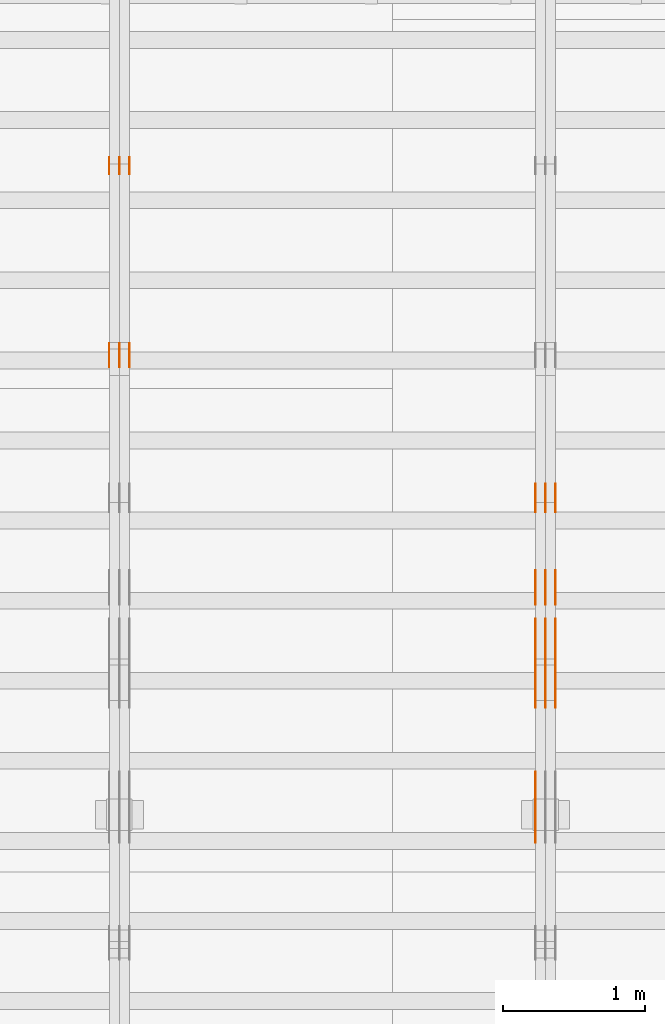
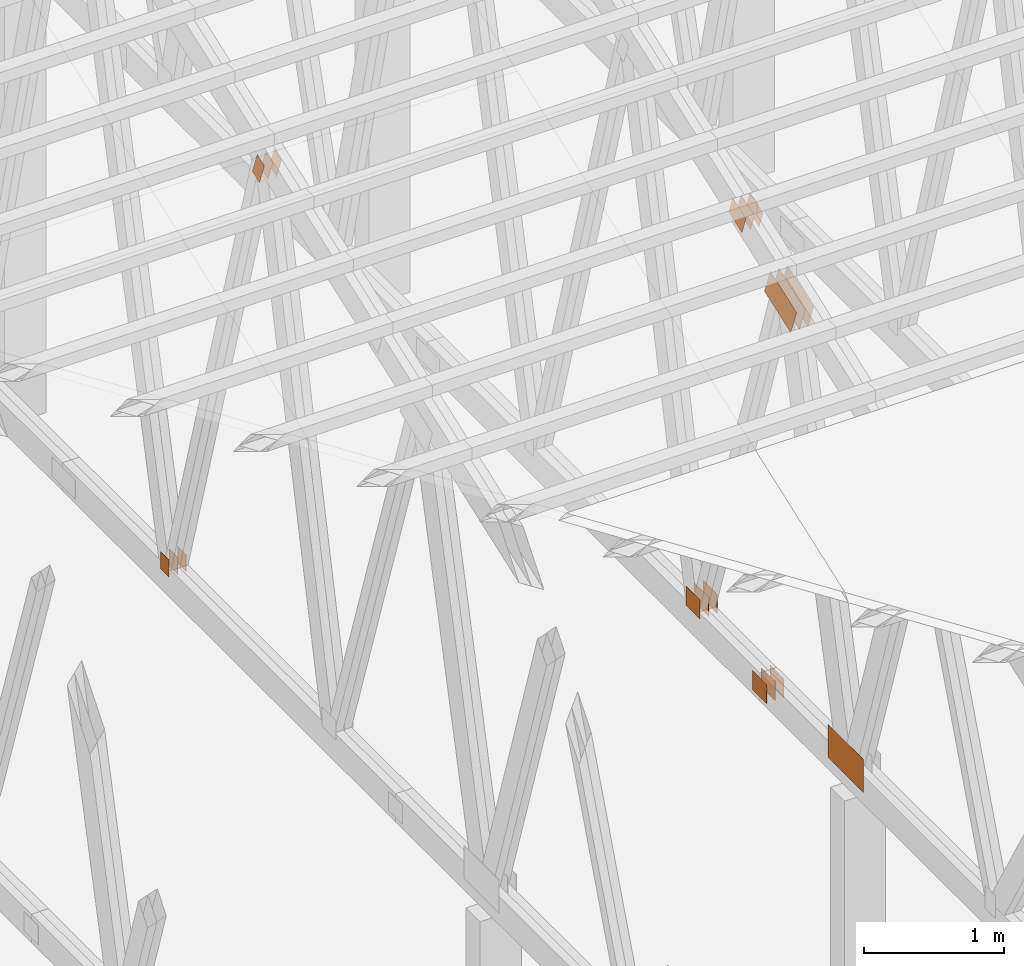
# One storey, part 146 of 189: 25 proxies.
"""IFC2X3 building model written with IfcOpenShell, lengths in millimetres."""

from ifc_helpers import new_model, entity, si_unit, converted_unit, derived_unit, direction, frame, frame_2d, origin, origin_2d_with_axis, place, context, subcontext, project, spatial, polyline, rectangle, outline, extrude, source, transform, mapped, material, type_object, type_shapes, element, save


model = new_model("IFC2X3")

# Units and contexts
model_context = context("Model", 3, precision=0.01, world=origin(), true_north=direction((6.12303176911189e-17, 1.0)))
body_context = subcontext(model_context, "Body", "Model", "MODEL_VIEW")
ifc_project = project(units=[si_unit("LENGTHUNIT", "METRE", prefix="MILLI"), si_unit("AREAUNIT", "SQUARE_METRE"), si_unit("VOLUMEUNIT", "CUBIC_METRE"), converted_unit("PLANEANGLEUNIT", "DEGREE", entity("IfcRatioMeasure", 0.0174532925199433), si_unit("PLANEANGLEUNIT", "RADIAN"), dimensions=[0, 0, 0, 0, 0, 0, 0]), si_unit("MASSUNIT", "GRAM", prefix="KILO"), derived_unit("MASSDENSITYUNIT", [(si_unit("MASSUNIT", "GRAM", prefix="KILO"), 1), (si_unit("LENGTHUNIT", "METRE"), -3)]), si_unit("TIMEUNIT", "SECOND"), si_unit("FREQUENCYUNIT", "HERTZ"), si_unit("THERMODYNAMICTEMPERATUREUNIT", "DEGREE_CELSIUS"), derived_unit("THERMALTRANSMITTANCEUNIT", [(si_unit("MASSUNIT", "GRAM", prefix="KILO"), 1), (si_unit("THERMODYNAMICTEMPERATUREUNIT", "KELVIN"), -1), (si_unit("TIMEUNIT", "SECOND"), -3)]), derived_unit("VOLUMETRICFLOWRATEUNIT", [(si_unit("LENGTHUNIT", "METRE"), 3), (si_unit("TIMEUNIT", "SECOND"), -1)]), si_unit("ELECTRICCURRENTUNIT", "AMPERE"), si_unit("ELECTRICVOLTAGEUNIT", "VOLT"), si_unit("POWERUNIT", "WATT"), si_unit("FORCEUNIT", "NEWTON"), si_unit("ILLUMINANCEUNIT", "LUX"), si_unit("LUMINOUSFLUXUNIT", "LUMEN"), si_unit("LUMINOUSINTENSITYUNIT", "CANDELA"), derived_unit("USERDEFINED", [(si_unit("MASSUNIT", "GRAM", prefix="KILO"), -1), (si_unit("LENGTHUNIT", "METRE"), -2), (si_unit("TIMEUNIT", "SECOND"), 3), (si_unit("LUMINOUSFLUXUNIT", "LUMEN"), 1)]), derived_unit("LINEARVELOCITYUNIT", [(si_unit("LENGTHUNIT", "METRE"), 1), (si_unit("TIMEUNIT", "SECOND"), -1)]), si_unit("PRESSUREUNIT", "PASCAL"), derived_unit("USERDEFINED", [(si_unit("LENGTHUNIT", "METRE"), -2), (si_unit("MASSUNIT", "GRAM", prefix="KILO"), 1), (si_unit("TIMEUNIT", "SECOND"), -2)])], contexts=[model_context])

# Site, building, storey
site_placement = place(None, origin())
site = spatial("IfcSite", under=ifc_project, at=site_placement, CompositionType="ELEMENT")
building_placement = place(site_placement, origin())
building = spatial("IfcBuilding", under=site, at=building_placement, CompositionType="ELEMENT")
storey_placement = place(building_placement, origin())
storey = spatial("IfcBuildingStorey", under=building, at=storey_placement, Name="Default", CompositionType="ELEMENT", Elevation=0.0)

# Proxies
ifc_material_1 = material(Name="IfcSurfaceStyle #203270")
building_element_proxy_type_1 = type_object("IfcBuildingElementProxyType", PredefinedType="NOTDEFINED", material=ifc_material_1)
shared_shape_1 = source(origin(), body_context, "Body", "SweptSolid", [
    extrude(rectangle(XDim=200.0, YDim=168.0, at=origin_2d_with_axis()), frame((100.000765376775, 84.0, 0.0), z_axis=(0.0, 0.0, 1.0), x_axis=(-1.0, 0.0, 0.0)), (0.0, 0.0, 1.0), 1.3),
])
type_shapes(building_element_proxy_type_1, [shared_shape_1])
proxy_1_placement = place(building_placement, frame((36301.3, 10880.1574377482, 365.0), z_axis=(-1.0, 0.0, 0.0), x_axis=(0.0, 1.0, 0.0)))
element("IfcBuildingElementProxy", 1, at=proxy_1_placement, inside=storey, type_object=building_element_proxy_type_1, material=ifc_material_1, context=body_context, shape_type="MappedRepresentation", body=[
    mapped(shared_shape_1, transform((0.0, 0.0, 0.0), scale=1.0)),
])
ifc_material_2 = material(Name="IfcSurfaceStyle #203213")
building_element_proxy_type_2 = type_object("IfcBuildingElementProxyType", PredefinedType="NOTDEFINED", material=ifc_material_2)
shared_shape_2 = source(origin(), body_context, "Body", "SweptSolid", [
    extrude(rectangle(XDim=200.0, YDim=168.0, at=origin_2d_with_axis()), frame((100.000765376775, 84.0, 0.0), z_axis=(0.0, 0.0, 1.0), x_axis=(-1.0, 0.0, 0.0)), (0.0, 0.0, 1.0), 1.29999999999998),
])
type_shapes(building_element_proxy_type_2, [shared_shape_2])
proxy_2_placement = place(building_placement, frame((36230.0, 10880.1574377482, 365.0), z_axis=(-1.0, 0.0, 0.0), x_axis=(0.0, 1.0, 0.0)))
element("IfcBuildingElementProxy", 2, at=proxy_2_placement, inside=storey, type_object=building_element_proxy_type_2, material=ifc_material_2, context=body_context, shape_type="MappedRepresentation", body=[
    mapped(shared_shape_2, transform((0.0, 0.0, 0.0), scale=1.0)),
])
ifc_material_3 = material(Name="IfcSurfaceStyle #203156")
building_element_proxy_type_3 = type_object("IfcBuildingElementProxyType", PredefinedType="NOTDEFINED", material=ifc_material_3)
shared_shape_3 = source(origin(), body_context, "Body", "SweptSolid", [
    extrude(rectangle(XDim=200.0, YDim=168.0, at=origin_2d_with_axis()), frame((100.000765376775, 84.0, 0.0), z_axis=(0.0, 0.0, 1.0), x_axis=(-1.0, 0.0, 0.0)), (0.0, 0.0, 1.0), 1.29999999999998),
])
type_shapes(building_element_proxy_type_3, [shared_shape_3])
proxy_3_placement = place(building_placement, frame((36231.3, 10880.1574377482, 365.0), z_axis=(-1.0, 0.0, 0.0), x_axis=(0.0, 1.0, 0.0)))
element("IfcBuildingElementProxy", 3, at=proxy_3_placement, inside=storey, type_object=building_element_proxy_type_3, material=ifc_material_3, context=body_context, shape_type="MappedRepresentation", body=[
    mapped(shared_shape_3, transform((0.0, 0.0, 0.0), scale=1.0)),
])
ifc_material_4 = material(Name="IfcSurfaceStyle #203099")
building_element_proxy_type_4 = type_object("IfcBuildingElementProxyType", PredefinedType="NOTDEFINED", material=ifc_material_4)
shared_shape_4 = source(origin(), body_context, "Body", "SweptSolid", [
    extrude(rectangle(XDim=200.0, YDim=168.0, at=origin_2d_with_axis()), frame((100.000765376775, 84.0, 0.0), z_axis=(0.0, 0.0, 1.0), x_axis=(-1.0, 0.0, 0.0)), (0.0, 0.0, 1.0), 1.29999999999999),
])
type_shapes(building_element_proxy_type_4, [shared_shape_4])
proxy_4_placement = place(building_placement, frame((36160.0, 10880.1574377482, 365.0), z_axis=(-1.0, 0.0, 0.0), x_axis=(0.0, 1.0, 0.0)))
element("IfcBuildingElementProxy", 4, at=proxy_4_placement, inside=storey, type_object=building_element_proxy_type_4, material=ifc_material_4, context=body_context, shape_type="MappedRepresentation", body=[
    mapped(shared_shape_4, transform((0.0, 0.0, 0.0), scale=1.0)),
])
ifc_material_5 = material(Name="IfcSurfaceStyle #203042")
building_element_proxy_type_5 = type_object("IfcBuildingElementProxyType", PredefinedType="NOTDEFINED", material=ifc_material_5)
shared_shape_5 = source(origin(), body_context, "Body", "SweptSolid", [
    extrude(outline(polyline([(-199.999582244654, -119.99984375717), (200.000344770932, -119.99984375717), (199.999582244655, 119.99984375717), (-200.000344770934, 119.99984375717), (-199.999582244654, -119.99984375717)])), frame((200.000344770932, 120.0000091947, 0.0), z_axis=(0.0, 0.0, 1.0), x_axis=(-1.0, 0.0, 0.0)), (0.0, 0.0, 1.0), 1.29999999999999),
])
type_shapes(building_element_proxy_type_5, [shared_shape_5])
proxy_5_placement = place(building_placement, frame((36301.3, 9961.90704972973, 3612.2451494258), z_axis=(-1.0, 0.0, 0.0), x_axis=(0.0, -0.939692620785908, -0.342020143325669)))
element("IfcBuildingElementProxy", 5, at=proxy_5_placement, inside=storey, type_object=building_element_proxy_type_5, material=ifc_material_5, context=body_context, shape_type="MappedRepresentation", body=[
    mapped(shared_shape_5, transform((0.0, 0.0, 0.0), scale=1.0)),
])
ifc_material_6 = material(Name="IfcSurfaceStyle #202985")
building_element_proxy_type_6 = type_object("IfcBuildingElementProxyType", PredefinedType="NOTDEFINED", material=ifc_material_6)
shared_shape_6 = source(origin(), body_context, "Body", "SweptSolid", [
    extrude(outline(polyline([(-199.999582244654, -119.99984375717), (200.000344770932, -119.99984375717), (199.999582244655, 119.99984375717), (-200.000344770934, 119.99984375717), (-199.999582244654, -119.99984375717)])), frame((200.000344770932, 120.0000091947, 0.0), z_axis=(0.0, 0.0, 1.0), x_axis=(-1.0, 0.0, 0.0)), (0.0, 0.0, 1.0), 1.29999999999997),
])
type_shapes(building_element_proxy_type_6, [shared_shape_6])
proxy_6_placement = place(building_placement, frame((36230.0, 9961.90704972973, 3612.2451494258), z_axis=(-1.0, 0.0, 0.0), x_axis=(0.0, -0.939692620785908, -0.342020143325669)))
element("IfcBuildingElementProxy", 6, at=proxy_6_placement, inside=storey, type_object=building_element_proxy_type_6, material=ifc_material_6, context=body_context, shape_type="MappedRepresentation", body=[
    mapped(shared_shape_6, transform((0.0, 0.0, 0.0), scale=1.0)),
])
ifc_material_7 = material(Name="IfcSurfaceStyle #202928")
building_element_proxy_type_7 = type_object("IfcBuildingElementProxyType", PredefinedType="NOTDEFINED", material=ifc_material_7)
shared_shape_7 = source(origin(), body_context, "Body", "SweptSolid", [
    extrude(outline(polyline([(-199.999582244654, -119.99984375717), (200.000344770932, -119.99984375717), (199.999582244655, 119.99984375717), (-200.000344770934, 119.99984375717), (-199.999582244654, -119.99984375717)])), frame((200.000344770932, 120.0000091947, 0.0), z_axis=(0.0, 0.0, 1.0), x_axis=(-1.0, 0.0, 0.0)), (0.0, 0.0, 1.0), 1.29999999999997),
])
type_shapes(building_element_proxy_type_7, [shared_shape_7])
proxy_7_placement = place(building_placement, frame((36231.3, 9961.90704972973, 3612.2451494258), z_axis=(-1.0, 0.0, 0.0), x_axis=(0.0, -0.939692620785908, -0.342020143325669)))
element("IfcBuildingElementProxy", 7, at=proxy_7_placement, inside=storey, type_object=building_element_proxy_type_7, material=ifc_material_7, context=body_context, shape_type="MappedRepresentation", body=[
    mapped(shared_shape_7, transform((0.0, 0.0, 0.0), scale=1.0)),
])
ifc_material_8 = material(Name="IfcSurfaceStyle #202871")
building_element_proxy_type_8 = type_object("IfcBuildingElementProxyType", PredefinedType="NOTDEFINED", material=ifc_material_8)
shared_shape_8 = source(origin(), body_context, "Body", "SweptSolid", [
    extrude(outline(polyline([(-199.999582244654, -119.99984375717), (200.000344770932, -119.99984375717), (199.999582244655, 119.99984375717), (-200.000344770934, 119.99984375717), (-199.999582244654, -119.99984375717)])), frame((200.000344770932, 120.0000091947, 0.0), z_axis=(0.0, 0.0, 1.0), x_axis=(-1.0, 0.0, 0.0)), (0.0, 0.0, 1.0), 1.29999999999998),
])
type_shapes(building_element_proxy_type_8, [shared_shape_8])
proxy_8_placement = place(building_placement, frame((36160.0, 9961.90704972973, 3612.2451494258), z_axis=(-1.0, 0.0, 0.0), x_axis=(0.0, -0.939692620785908, -0.342020143325669)))
element("IfcBuildingElementProxy", 8, at=proxy_8_placement, inside=storey, type_object=building_element_proxy_type_8, material=ifc_material_8, context=body_context, shape_type="MappedRepresentation", body=[
    mapped(shared_shape_8, transform((0.0, 0.0, 0.0), scale=1.0)),
])
ifc_material_9 = material(Name="IfcSurfaceStyle #202187")
building_element_proxy_type_9 = type_object("IfcBuildingElementProxyType", PredefinedType="NOTDEFINED", material=ifc_material_9)
shared_shape_9 = source(origin(), body_context, "Body", "SweptSolid", [
    extrude(rectangle(XDim=500.0, YDim=288.0, at=frame_2d((0.0, 1.4210854715202e-14), x_axis=(1.0, 0.0))), frame((250.000973740011, 144.0, 0.0), z_axis=(0.0, 0.0, 1.0), x_axis=(-1.0, 0.0, 0.0)), (0.0, 0.0, 1.0), 1.29999999999997),
])
type_shapes(building_element_proxy_type_9, [shared_shape_9])
proxy_9_placement = place(building_placement, frame((36160.0, 8551.90918250999, 389.0), z_axis=(-1.0, 0.0, 0.0), x_axis=(0.0, 1.0, 0.0)))
element("IfcBuildingElementProxy", 9, at=proxy_9_placement, inside=storey, type_object=building_element_proxy_type_9, material=ifc_material_9, context=body_context, shape_type="MappedRepresentation", body=[
    mapped(shared_shape_9, transform((0.0, 0.0, 0.0), scale=1.0)),
])
ifc_material_10 = material(Name="IfcSurfaceStyle #196718")
building_element_proxy_type_10 = type_object("IfcBuildingElementProxyType", PredefinedType="NOTDEFINED", material=ifc_material_10)
shared_shape_10 = source(origin(), body_context, "Body", "SweptSolid", [
    extrude(rectangle(XDim=200.0, YDim=168.0, at=origin_2d_with_axis()), frame((100.0, 84.0, 0.0), z_axis=(0.0, 0.0, 1.0), x_axis=(-1.0, 0.0, 0.0)), (0.0, 0.0, 1.0), 1.3),
])
type_shapes(building_element_proxy_type_10, [shared_shape_10])
proxy_10_placement = place(building_placement, frame((36301.3, 9929.23046875, 206.5), z_axis=(-1.0, 0.0, 0.0), x_axis=(0.0, 1.0, 0.0)))
element("IfcBuildingElementProxy", 10, at=proxy_10_placement, inside=storey, type_object=building_element_proxy_type_10, material=ifc_material_10, context=body_context, shape_type="MappedRepresentation", body=[
    mapped(shared_shape_10, transform((0.0, 0.0, 0.0), scale=1.0)),
])
ifc_material_11 = material(Name="IfcSurfaceStyle #196661")
building_element_proxy_type_11 = type_object("IfcBuildingElementProxyType", PredefinedType="NOTDEFINED", material=ifc_material_11)
shared_shape_11 = source(origin(), body_context, "Body", "SweptSolid", [
    extrude(rectangle(XDim=200.0, YDim=168.0, at=origin_2d_with_axis()), frame((100.0, 84.0, 0.0), z_axis=(0.0, 0.0, 1.0), x_axis=(-1.0, 0.0, 0.0)), (0.0, 0.0, 1.0), 1.29999999999998),
])
type_shapes(building_element_proxy_type_11, [shared_shape_11])
proxy_11_placement = place(building_placement, frame((36230.0, 9929.23046875, 206.5), z_axis=(-1.0, 0.0, 0.0), x_axis=(0.0, 1.0, 0.0)))
element("IfcBuildingElementProxy", 11, at=proxy_11_placement, inside=storey, type_object=building_element_proxy_type_11, material=ifc_material_11, context=body_context, shape_type="MappedRepresentation", body=[
    mapped(shared_shape_11, transform((0.0, 0.0, 0.0), scale=1.0)),
])
ifc_material_12 = material(Name="IfcSurfaceStyle #196604")
building_element_proxy_type_12 = type_object("IfcBuildingElementProxyType", PredefinedType="NOTDEFINED", material=ifc_material_12)
shared_shape_12 = source(origin(), body_context, "Body", "SweptSolid", [
    extrude(rectangle(XDim=200.0, YDim=168.0, at=origin_2d_with_axis()), frame((100.0, 84.0, 0.0), z_axis=(0.0, 0.0, 1.0), x_axis=(-1.0, 0.0, 0.0)), (0.0, 0.0, 1.0), 1.29999999999998),
])
type_shapes(building_element_proxy_type_12, [shared_shape_12])
proxy_12_placement = place(building_placement, frame((36231.3, 9929.23046875, 206.5), z_axis=(-1.0, 0.0, 0.0), x_axis=(0.0, 1.0, 0.0)))
element("IfcBuildingElementProxy", 12, at=proxy_12_placement, inside=storey, type_object=building_element_proxy_type_12, material=ifc_material_12, context=body_context, shape_type="MappedRepresentation", body=[
    mapped(shared_shape_12, transform((0.0, 0.0, 0.0), scale=1.0)),
])
ifc_material_13 = material(Name="IfcSurfaceStyle #196547")
building_element_proxy_type_13 = type_object("IfcBuildingElementProxyType", PredefinedType="NOTDEFINED", material=ifc_material_13)
shared_shape_13 = source(origin(), body_context, "Body", "SweptSolid", [
    extrude(rectangle(XDim=200.0, YDim=168.0, at=origin_2d_with_axis()), frame((100.0, 84.0, 0.0), z_axis=(0.0, 0.0, 1.0), x_axis=(-1.0, 0.0, 0.0)), (0.0, 0.0, 1.0), 1.29999999999999),
])
type_shapes(building_element_proxy_type_13, [shared_shape_13])
proxy_13_placement = place(building_placement, frame((36160.0, 9929.23046875, 206.5), z_axis=(-1.0, 0.0, 0.0), x_axis=(0.0, 1.0, 0.0)))
element("IfcBuildingElementProxy", 13, at=proxy_13_placement, inside=storey, type_object=building_element_proxy_type_13, material=ifc_material_13, context=body_context, shape_type="MappedRepresentation", body=[
    mapped(shared_shape_13, transform((0.0, 0.0, 0.0), scale=1.0)),
])
ifc_material_14 = material(Name="IfcSurfaceStyle #195638")
building_element_proxy_type_14 = type_object("IfcBuildingElementProxyType", PredefinedType="NOTDEFINED", material=ifc_material_14)
shared_shape_14 = source(origin(), body_context, "Body", "SweptSolid", [
    extrude(outline(polyline([(-100.00072430513, -84.0000258989549), (100.000156871239, -84.0000258989549), (99.9997648860508, 84.0000258989549), (-99.9991974521591, 84.0000258989548), (-100.00072430513, -84.0000258989549)])), frame((100.000156871239, 84.0000258989548, 0.0), z_axis=(0.0, 0.0, 1.0), x_axis=(-1.0, 0.0, 0.0)), (0.0, 0.0, 1.0), 1.3),
])
type_shapes(building_element_proxy_type_14, [shared_shape_14])
proxy_14_placement = place(building_placement, frame((36301.3, 10226.4409888304, 4081.14941482552), z_axis=(-1.0, 0.0, 0.0), x_axis=(0.0, 0.939692620785908, 0.342020143325669)))
element("IfcBuildingElementProxy", 14, at=proxy_14_placement, inside=storey, type_object=building_element_proxy_type_14, material=ifc_material_14, context=body_context, shape_type="MappedRepresentation", body=[
    mapped(shared_shape_14, transform((0.0, 0.0, 0.0), scale=1.0)),
])
ifc_material_15 = material(Name="IfcSurfaceStyle #195581")
building_element_proxy_type_15 = type_object("IfcBuildingElementProxyType", PredefinedType="NOTDEFINED", material=ifc_material_15)
shared_shape_15 = source(origin(), body_context, "Body", "SweptSolid", [
    extrude(outline(polyline([(-100.00072430513, -84.0000258989549), (100.000156871239, -84.0000258989549), (99.9997648860508, 84.0000258989549), (-99.9991974521591, 84.0000258989548), (-100.00072430513, -84.0000258989549)])), frame((100.000156871239, 84.0000258989548, 0.0), z_axis=(0.0, 0.0, 1.0), x_axis=(-1.0, 0.0, 0.0)), (0.0, 0.0, 1.0), 1.29999999999998),
])
type_shapes(building_element_proxy_type_15, [shared_shape_15])
proxy_15_placement = place(building_placement, frame((36230.0, 10226.4409888304, 4081.14941482552), z_axis=(-1.0, 0.0, 0.0), x_axis=(0.0, 0.939692620785908, 0.342020143325669)))
element("IfcBuildingElementProxy", 15, at=proxy_15_placement, inside=storey, type_object=building_element_proxy_type_15, material=ifc_material_15, context=body_context, shape_type="MappedRepresentation", body=[
    mapped(shared_shape_15, transform((0.0, 0.0, 0.0), scale=1.0)),
])
ifc_material_16 = material(Name="IfcSurfaceStyle #195524")
building_element_proxy_type_16 = type_object("IfcBuildingElementProxyType", PredefinedType="NOTDEFINED", material=ifc_material_16)
shared_shape_16 = source(origin(), body_context, "Body", "SweptSolid", [
    extrude(outline(polyline([(-100.00072430513, -84.0000258989549), (100.000156871239, -84.0000258989549), (99.9997648860508, 84.0000258989549), (-99.9991974521591, 84.0000258989548), (-100.00072430513, -84.0000258989549)])), frame((100.000156871239, 84.0000258989548, 0.0), z_axis=(0.0, 0.0, 1.0), x_axis=(-1.0, 0.0, 0.0)), (0.0, 0.0, 1.0), 1.29999999999998),
])
type_shapes(building_element_proxy_type_16, [shared_shape_16])
proxy_16_placement = place(building_placement, frame((36231.3, 10226.4409888304, 4081.14941482552), z_axis=(-1.0, 0.0, 0.0), x_axis=(0.0, 0.939692620785908, 0.342020143325669)))
element("IfcBuildingElementProxy", 16, at=proxy_16_placement, inside=storey, type_object=building_element_proxy_type_16, material=ifc_material_16, context=body_context, shape_type="MappedRepresentation", body=[
    mapped(shared_shape_16, transform((0.0, 0.0, 0.0), scale=1.0)),
])
ifc_material_17 = material(Name="IfcSurfaceStyle #195467")
building_element_proxy_type_17 = type_object("IfcBuildingElementProxyType", PredefinedType="NOTDEFINED", material=ifc_material_17)
shared_shape_17 = source(origin(), body_context, "Body", "SweptSolid", [
    extrude(outline(polyline([(-100.00072430513, -84.0000258989549), (100.000156871239, -84.0000258989549), (99.9997648860508, 84.0000258989549), (-99.9991974521591, 84.0000258989548), (-100.00072430513, -84.0000258989549)])), frame((100.000156871239, 84.0000258989548, 0.0), z_axis=(0.0, 0.0, 1.0), x_axis=(-1.0, 0.0, 0.0)), (0.0, 0.0, 1.0), 1.29999999999999),
])
type_shapes(building_element_proxy_type_17, [shared_shape_17])
proxy_17_placement = place(building_placement, frame((36160.0, 10226.4409888304, 4081.14941482552), z_axis=(-1.0, 0.0, 0.0), x_axis=(0.0, 0.939692620785908, 0.342020143325669)))
element("IfcBuildingElementProxy", 17, at=proxy_17_placement, inside=storey, type_object=building_element_proxy_type_17, material=ifc_material_17, context=body_context, shape_type="MappedRepresentation", body=[
    mapped(shared_shape_17, transform((0.0, 0.0, 0.0), scale=1.0)),
])
ifc_material_18 = material(Name="IfcSurfaceStyle #188848")
building_element_proxy_type_18 = type_object("IfcBuildingElementProxyType", PredefinedType="NOTDEFINED", material=ifc_material_18)
shared_shape_18 = source(origin(), body_context, "Body", "SweptSolid", [
    extrude(rectangle(XDim=150.0, YDim=120.0, at=origin_2d_with_axis()), frame((75.0, 60.0000682744794, 0.0), z_axis=(0.0, 0.0, 1.0), x_axis=(-1.0, 0.0, 0.0)), (0.0, 0.0, 1.0), 1.3),
])
type_shapes(building_element_proxy_type_18, [shared_shape_18])
proxy_18_placement = place(building_placement, frame((33301.3, 13259.2753223505, 170.0), z_axis=(-1.0, 0.0, 0.0), x_axis=(0.0, 0.0, 1.0)))
element("IfcBuildingElementProxy", 18, at=proxy_18_placement, inside=storey, type_object=building_element_proxy_type_18, material=ifc_material_18, context=body_context, shape_type="MappedRepresentation", body=[
    mapped(shared_shape_18, transform((0.0, 0.0, 0.0), scale=1.0)),
])
ifc_material_19 = material(Name="IfcSurfaceStyle #188791")
building_element_proxy_type_19 = type_object("IfcBuildingElementProxyType", PredefinedType="NOTDEFINED", material=ifc_material_19)
shared_shape_19 = source(origin(), body_context, "Body", "SweptSolid", [
    extrude(rectangle(XDim=150.0, YDim=120.0, at=origin_2d_with_axis()), frame((75.0, 60.0000682744794, 0.0), z_axis=(0.0, 0.0, 1.0), x_axis=(-1.0, 0.0, 0.0)), (0.0, 0.0, 1.0), 1.29999999999999),
])
type_shapes(building_element_proxy_type_19, [shared_shape_19])
proxy_19_placement = place(building_placement, frame((33230.0, 13259.2753223505, 170.0), z_axis=(-1.0, 0.0, 0.0), x_axis=(0.0, 0.0, 1.0)))
element("IfcBuildingElementProxy", 19, at=proxy_19_placement, inside=storey, type_object=building_element_proxy_type_19, material=ifc_material_19, context=body_context, shape_type="MappedRepresentation", body=[
    mapped(shared_shape_19, transform((0.0, 0.0, 0.0), scale=1.0)),
])
ifc_material_20 = material(Name="IfcSurfaceStyle #188734")
building_element_proxy_type_20 = type_object("IfcBuildingElementProxyType", PredefinedType="NOTDEFINED", material=ifc_material_20)
shared_shape_20 = source(origin(), body_context, "Body", "SweptSolid", [
    extrude(rectangle(XDim=150.0, YDim=120.0, at=origin_2d_with_axis()), frame((75.0, 60.0000682744794, 0.0), z_axis=(0.0, 0.0, 1.0), x_axis=(-1.0, 0.0, 0.0)), (0.0, 0.0, 1.0), 1.29999999999999),
])
type_shapes(building_element_proxy_type_20, [shared_shape_20])
proxy_20_placement = place(building_placement, frame((33231.3, 13259.2753223505, 170.0), z_axis=(-1.0, 0.0, 0.0), x_axis=(0.0, 0.0, 1.0)))
element("IfcBuildingElementProxy", 20, at=proxy_20_placement, inside=storey, type_object=building_element_proxy_type_20, material=ifc_material_20, context=body_context, shape_type="MappedRepresentation", body=[
    mapped(shared_shape_20, transform((0.0, 0.0, 0.0), scale=1.0)),
])
ifc_material_21 = material(Name="IfcSurfaceStyle #188677")
building_element_proxy_type_21 = type_object("IfcBuildingElementProxyType", PredefinedType="NOTDEFINED", material=ifc_material_21)
shared_shape_21 = source(origin(), body_context, "Body", "SweptSolid", [
    extrude(rectangle(XDim=150.0, YDim=120.0, at=origin_2d_with_axis()), frame((75.0, 60.0000682744794, 0.0), z_axis=(0.0, 0.0, 1.0), x_axis=(-1.0, 0.0, 0.0)), (0.0, 0.0, 1.0), 1.29999999999999),
])
type_shapes(building_element_proxy_type_21, [shared_shape_21])
proxy_21_placement = place(building_placement, frame((33160.0, 13259.2753223505, 170.0), z_axis=(-1.0, 0.0, 0.0), x_axis=(0.0, 0.0, 1.0)))
element("IfcBuildingElementProxy", 21, at=proxy_21_placement, inside=storey, type_object=building_element_proxy_type_21, material=ifc_material_21, context=body_context, shape_type="MappedRepresentation", body=[
    mapped(shared_shape_21, transform((0.0, 0.0, 0.0), scale=1.0)),
])
ifc_material_22 = material(Name="IfcSurfaceStyle #188164")
building_element_proxy_type_22 = type_object("IfcBuildingElementProxyType", PredefinedType="NOTDEFINED", material=ifc_material_22)
shared_shape_22 = source(origin(), body_context, "Body", "SweptSolid", [
    extrude(outline(polyline([(-54.000518665753, -99.9999712116328), (54.0009733694842, -99.9999712116328), (53.9996516525364, 99.999866626518), (-54.0001063562676, 100.000075796748), (-54.000518665753, -99.9999712116328)])), frame((100.000049683045, 54.0003125110034, 0.0), z_axis=(0.0, 0.0, 1.0), x_axis=(-2.06154694206879e-06, 1.0, 0.0)), (0.0, 0.0, 1.0), 1.3),
])
type_shapes(building_element_proxy_type_22, [shared_shape_22])
proxy_22_placement = place(building_placement, frame((33301.3, 12002.0392854883, 4614.07927340247), z_axis=(-1.0, 0.0, 0.0), x_axis=(0.0, 0.342020143325669, -0.939692620785908)))
element("IfcBuildingElementProxy", 22, at=proxy_22_placement, inside=storey, type_object=building_element_proxy_type_22, material=ifc_material_22, context=body_context, shape_type="MappedRepresentation", body=[
    mapped(shared_shape_22, transform((0.0, 0.0, 0.0), scale=1.0)),
])
ifc_material_23 = material(Name="IfcSurfaceStyle #188107")
building_element_proxy_type_23 = type_object("IfcBuildingElementProxyType", PredefinedType="NOTDEFINED", material=ifc_material_23)
shared_shape_23 = source(origin(), body_context, "Body", "SweptSolid", [
    extrude(outline(polyline([(-54.000518665753, -99.9999712116328), (54.0009733694842, -99.9999712116328), (53.9996516525364, 99.999866626518), (-54.0001063562676, 100.000075796748), (-54.000518665753, -99.9999712116328)])), frame((100.000049683045, 54.0003125110034, 0.0), z_axis=(0.0, 0.0, 1.0), x_axis=(-2.06154694206879e-06, 1.0, 0.0)), (0.0, 0.0, 1.0), 1.29999999999998),
])
type_shapes(building_element_proxy_type_23, [shared_shape_23])
proxy_23_placement = place(building_placement, frame((33230.0, 12002.0392854883, 4614.07927340247), z_axis=(-1.0, 0.0, 0.0), x_axis=(0.0, 0.342020143325669, -0.939692620785908)))
element("IfcBuildingElementProxy", 23, at=proxy_23_placement, inside=storey, type_object=building_element_proxy_type_23, material=ifc_material_23, context=body_context, shape_type="MappedRepresentation", body=[
    mapped(shared_shape_23, transform((0.0, 0.0, 0.0), scale=1.0)),
])
ifc_material_24 = material(Name="IfcSurfaceStyle #188050")
building_element_proxy_type_24 = type_object("IfcBuildingElementProxyType", PredefinedType="NOTDEFINED", material=ifc_material_24)
shared_shape_24 = source(origin(), body_context, "Body", "SweptSolid", [
    extrude(outline(polyline([(-54.000518665753, -99.9999712116328), (54.0009733694842, -99.9999712116328), (53.9996516525364, 99.999866626518), (-54.0001063562676, 100.000075796748), (-54.000518665753, -99.9999712116328)])), frame((100.000049683045, 54.0003125110034, 0.0), z_axis=(0.0, 0.0, 1.0), x_axis=(-2.06154694206879e-06, 1.0, 0.0)), (0.0, 0.0, 1.0), 1.29999999999998),
])
type_shapes(building_element_proxy_type_24, [shared_shape_24])
proxy_24_placement = place(building_placement, frame((33231.3, 12002.0392854883, 4614.07927340247), z_axis=(-1.0, 0.0, 0.0), x_axis=(0.0, 0.342020143325669, -0.939692620785908)))
element("IfcBuildingElementProxy", 24, at=proxy_24_placement, inside=storey, type_object=building_element_proxy_type_24, material=ifc_material_24, context=body_context, shape_type="MappedRepresentation", body=[
    mapped(shared_shape_24, transform((0.0, 0.0, 0.0), scale=1.0)),
])
ifc_material_25 = material(Name="IfcSurfaceStyle #187993")
building_element_proxy_type_25 = type_object("IfcBuildingElementProxyType", PredefinedType="NOTDEFINED", material=ifc_material_25)
shared_shape_25 = source(origin(), body_context, "Body", "SweptSolid", [
    extrude(outline(polyline([(-54.000518665753, -99.9999712116328), (54.0009733694842, -99.9999712116328), (53.9996516525364, 99.999866626518), (-54.0001063562676, 100.000075796748), (-54.000518665753, -99.9999712116328)])), frame((100.000049683045, 54.0003125110034, 0.0), z_axis=(0.0, 0.0, 1.0), x_axis=(-2.06154694206879e-06, 1.0, 0.0)), (0.0, 0.0, 1.0), 1.29999999999999),
])
type_shapes(building_element_proxy_type_25, [shared_shape_25])
proxy_25_placement = place(building_placement, frame((33160.0, 12002.0392854883, 4614.07927340247), z_axis=(-1.0, 0.0, 0.0), x_axis=(0.0, 0.342020143325669, -0.939692620785908)))
element("IfcBuildingElementProxy", 25, at=proxy_25_placement, inside=storey, type_object=building_element_proxy_type_25, material=ifc_material_25, context=body_context, shape_type="MappedRepresentation", body=[
    mapped(shared_shape_25, transform((0.0, 0.0, 0.0), scale=1.0)),
])

save(model, "model.ifc")
